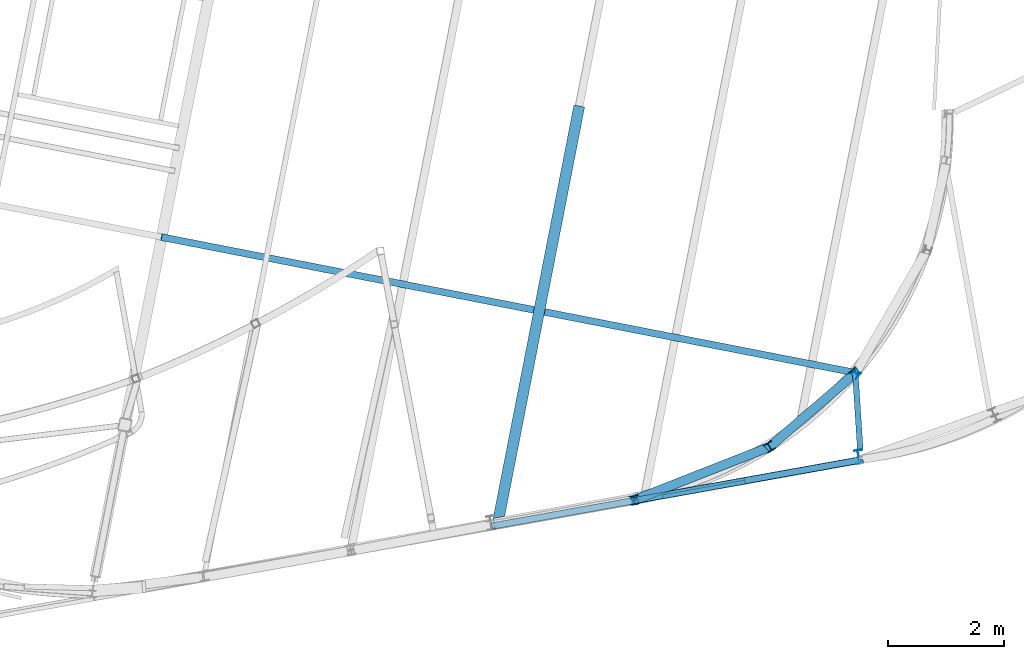
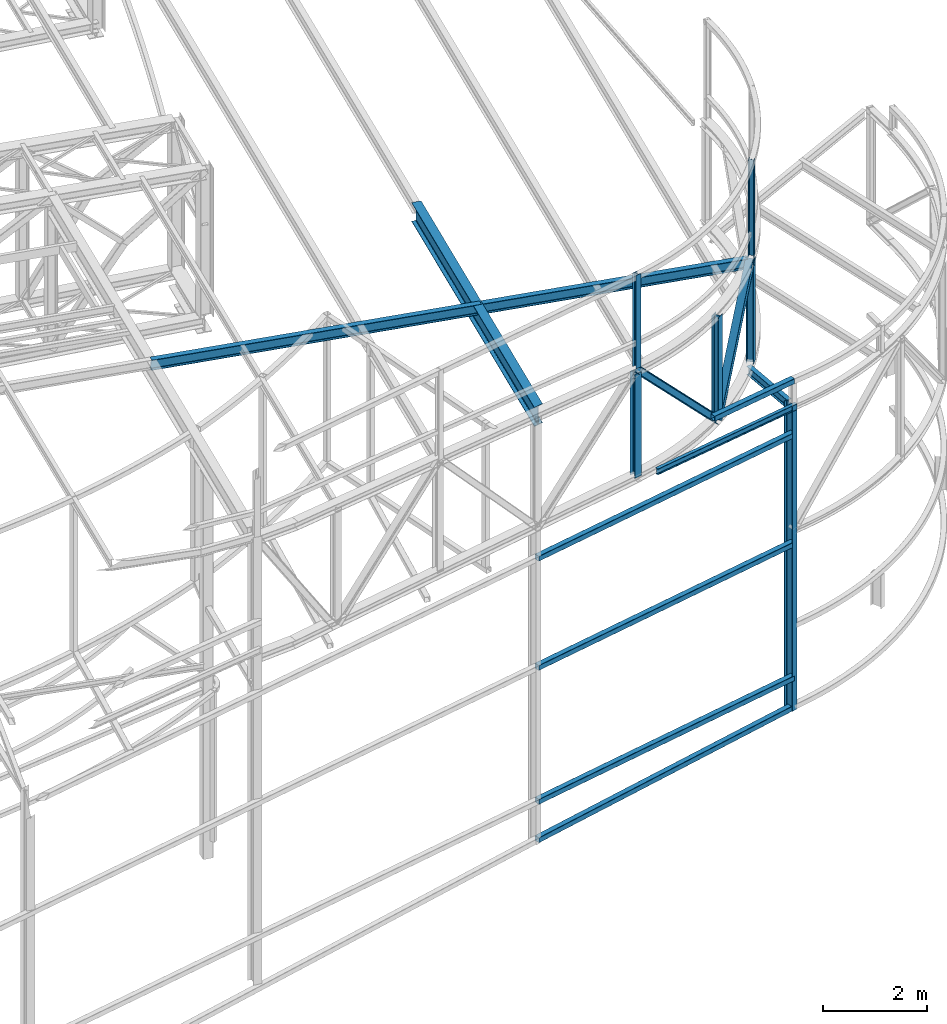
# One storey, part 58 of 215: 15 beams, 2 members, 17 elements without a shape of their own.
"""IFC2X3 building model written with IfcOpenShell, lengths in millimetres."""

from ifc_helpers import new_model, si_unit, frame, origin_with_axes, origin_2d_with_axis, place, context, subcontext, project, spatial, hollow_rectangle, i_section, extrude, clip, halfspace, material, type_object, element, aggregate, save


model = new_model("IFC2X3")

# Units and contexts
model_context = context("Model", 3, precision=1e-05, world=origin_with_axes())
body_context = subcontext(model_context, "Body", "Model", "MODEL_VIEW")
ifc_project = project(units=[si_unit("LENGTHUNIT", "METRE", prefix="MILLI"), si_unit("AREAUNIT", "SQUARE_METRE"), si_unit("VOLUMEUNIT", "CUBIC_METRE"), si_unit("MASSUNIT", "GRAM", prefix="KILO"), si_unit("TIMEUNIT", "SECOND"), si_unit("PLANEANGLEUNIT", "RADIAN"), si_unit("SOLIDANGLEUNIT", "STERADIAN"), si_unit("THERMODYNAMICTEMPERATUREUNIT", "DEGREE_CELSIUS"), si_unit("LUMINOUSINTENSITYUNIT", "LUMEN")], contexts=[model_context])

# Site, building, storey
site_placement = place(None, origin_with_axes())
site = spatial("IfcSite", under=ifc_project, at=site_placement, CompositionType="ELEMENT")
building_placement = place(site_placement, origin_with_axes())
building = spatial("IfcBuilding", under=site, at=building_placement, Name="Undefined", CompositionType="ELEMENT")
storey_placement = place(building_placement, origin_with_axes())
storey = spatial("IfcBuildingStorey", under=building, at=storey_placement, Name="Undefined", CompositionType="ELEMENT", Elevation=0.0)

# Assembly, beam
assembly_1_placement = place(storey_placement, origin_with_axes())
assembly_1 = element("IfcElementAssembly", 1, at=assembly_1_placement, inside=storey, Name="Steel Assembly", AssemblyPlace="NOTDEFINED", PredefinedType="RIGID_FRAME")
ifc_material = material(Name="STEEL/S275JR")
beam_type_1 = type_object("IfcBeamType", Name="IPE240", PredefinedType="NOTDEFINED")
beam_1_placement = place(assembly_1_placement, frame((97347.3851867053, 4087.84249486251, 9374.31892588978), z_axis=(-0.1771386489551, 0.98418590675053, -1.00000033828228e-09), x_axis=(0.0, 0.0, -1.0)))
beam_1 = element("IfcBeam", 2, at=beam_1_placement, type_object=beam_type_1, material=ifc_material, Name="MONTANT", ObjectType="IPE240", context=body_context, shape_type="Clipping", body=[
    clip(extrude(i_section(OverallWidth=120.0, OverallDepth=240.0, WebThickness=6.199999809, FlangeThickness=9.800000191, FilletRadius=15.0, at=origin_2d_with_axis()), frame((7146.48272238819, 1.84732248622022e-22, -1.47785798897617e-21), z_axis=(-1.0, 0.0, 0.0), x_axis=(-6.93889390390723e-18, -1.0, -3.46944695195361e-18)), (0.0, 0.0, 1.0), 7146.5), halfspace(frame((7147.85210151617, 93.6102312018338, -108.961109447533), z_axis=(-0.999134504355505, 0.0415961747295458, 2.13107609228816e-05), x_axis=(-1.00009037889739e-09, -0.000512348971731184, 0.999999868749257)), True)),
])
aggregate(assembly_1, [beam_1])

assembly_2_placement = place(storey_placement, origin_with_axes())
assembly_2 = element("IfcElementAssembly", 3, at=assembly_2_placement, inside=storey, Name="Steel Assembly", AssemblyPlace="NOTDEFINED", PredefinedType="RIGID_FRAME")
beam_2_placement = place(assembly_2_placement, frame((97223.4923669423, 5546.1113580424, 11815.5512887508), z_axis=(0.0304080349965938, -0.00594450399933318, 0.999519891888024), x_axis=(-0.980951221876683, 0.191767344975893, 0.0309836359961049)))
beam_2 = element("IfcBeam", 4, at=beam_2_placement, type_object=beam_type_1, material=ifc_material, Name="TRAVERSE", ObjectType="IPE240", context=body_context, shape_type="SweptSolid", body=[
    extrude(i_section(OverallWidth=120.0, OverallDepth=240.0, WebThickness=6.199999809, FlangeThickness=9.800000191, FilletRadius=15.0, at=origin_2d_with_axis()), frame((12102.0453081629, 2.8537076156674e-12, 8.39748084136206e-14), z_axis=(-1.0, 0.0, 0.0), x_axis=(-6.93889390390723e-18, -1.0, -3.46944695195361e-18)), (0.0, 0.0, 1.0), 12102.0),
])
aggregate(assembly_2, [beam_2])

assembly_3_placement = place(storey_placement, origin_with_axes())
assembly_3 = element("IfcElementAssembly", 5, at=assembly_3_placement, inside=storey, Name="Steel Assembly", AssemblyPlace="NOTDEFINED", PredefinedType="RIGID_FRAME")
beam_type_2 = type_object("IfcBeamType", PredefinedType="NOTDEFINED")
beam_3_placement = place(assembly_3_placement, frame((97357.4855771362, 4028.69337926281, 9936.18618551114), z_axis=(0.0108940300050036, 0.0019528030008978, 0.999938751459653), x_axis=(-0.984250728592777, -0.176431317927004, 0.0110676699954206)))
beam_3 = element("IfcBeam", 6, at=beam_3_placement, type_object=beam_type_2, material=ifc_material, Name="LISSE", context=body_context, shape_type="SweptSolid", body=[
    extrude(hollow_rectangle(XDim=120.0, YDim=120.0, WallThickness=4.0, InnerFilletRadius=4.0, OuterFilletRadius=8.0, at=origin_2d_with_axis()), frame((2004.11588056568, 1.47251628963692e-14, 1.81898940354586e-12), z_axis=(-1.0, 0.0, 0.0), x_axis=(-6.93889390390723e-18, -1.0, -3.46944695195361e-18)), (0.0, 0.0, 1.0), 2004.1),
])
aggregate(assembly_3, [beam_3])

assembly_4_placement = place(storey_placement, origin_with_axes())
assembly_4 = element("IfcElementAssembly", 7, at=assembly_4_placement, inside=storey, Name="Steel Assembly", AssemblyPlace="NOTDEFINED", PredefinedType="RIGID_FRAME")
beam_type_3 = type_object("IfcBeamType", PredefinedType="NOTDEFINED")
beam_4_placement = place(assembly_4_placement, frame((91037.8229060199, 2893.15712750791, 2980.9622243979), z_axis=(-0.176633325081884, 0.98427672345628, -1.15190000054747e-05), x_axis=(0.98427672355278, 0.176633324919744, 0.0)))
beam_4 = element("IfcBeam", 8, at=beam_4_placement, type_object=beam_type_3, material=ifc_material, Name="LISSE", context=body_context, shape_type="SweptSolid", body=[
    extrude(hollow_rectangle(XDim=120.0, YDim=120.0, WallThickness=5.0, InnerFilletRadius=5.0, OuterFilletRadius=10.0, at=origin_2d_with_axis()), frame((6421.60160180629, -4.54744631232399e-13, 3.45974355825933e-12), z_axis=(-1.0, 0.0, 0.0), x_axis=(-6.93889390390723e-18, -1.0, -3.46944695195361e-18)), (0.0, 0.0, 1.0), 6421.6),
])
aggregate(assembly_4, [beam_4])

assembly_5_placement = place(storey_placement, origin_with_axes())
assembly_5 = element("IfcElementAssembly", 9, at=assembly_5_placement, inside=storey, Name="Steel Assembly", AssemblyPlace="NOTDEFINED", PredefinedType="RIGID_FRAME")
beam_5_placement = place(assembly_5_placement, frame((91037.6728468908, 2894.57214630416, 2080.37507932096), z_axis=(-0.176634917931537, 0.984276437618519, -1.07849999957617e-05), x_axis=(0.983738704753266, 0.176538779955722, 0.0330487509917109)))
beam_5 = element("IfcBeam", 10, at=beam_5_placement, type_object=beam_type_3, material=ifc_material, Name="LISSE", context=body_context, shape_type="SweptSolid", body=[
    extrude(hollow_rectangle(XDim=120.0, YDim=120.0, WallThickness=5.0, InnerFilletRadius=5.0, OuterFilletRadius=10.0, at=origin_2d_with_axis()), frame((6354.06246759714, 1.83283510121777e-13, -7.68668195172968e-14), z_axis=(-1.0, 0.0, 0.0), x_axis=(-6.93889390390723e-18, -1.0, -3.46944695195361e-18)), (0.0, 0.0, 1.0), 6354.1),
])
aggregate(assembly_5, [beam_5])

assembly_6_placement = place(storey_placement, origin_with_axes())
assembly_6 = element("IfcElementAssembly", 11, at=assembly_6_placement, inside=storey, Name="Steel Assembly", AssemblyPlace="NOTDEFINED", PredefinedType="RIGID_FRAME")
beam_6_placement = place(assembly_6_placement, frame((91034.3598653981, 2893.97881739079, 6117.50421487598), z_axis=(-0.176633325081884, 0.98427672345628, -1.15190000054747e-05), x_axis=(0.98427672355278, 0.176633324919744, 0.0)))
beam_6 = element("IfcBeam", 12, at=beam_6_placement, type_object=beam_type_3, material=ifc_material, Name="LISSE", context=body_context, shape_type="SweptSolid", body=[
    extrude(hollow_rectangle(XDim=120.0, YDim=120.0, WallThickness=5.0, InnerFilletRadius=5.0, OuterFilletRadius=10.0, at=origin_2d_with_axis()), frame((6421.60160180629, -4.54744631232399e-13, 3.45974355825933e-12), z_axis=(-1.0, 0.0, 0.0), x_axis=(-6.93889390390723e-18, -1.0, -3.46944695195361e-18)), (0.0, 0.0, 1.0), 6421.6),
])
aggregate(assembly_6, [beam_6])

assembly_7_placement = place(storey_placement, origin_with_axes())
assembly_7 = element("IfcElementAssembly", 13, at=assembly_7_placement, inside=storey, Name="Steel Assembly", AssemblyPlace="NOTDEFINED", PredefinedType="RIGID_FRAME")
beam_7_placement = place(assembly_7_placement, frame((91034.3598658139, 2893.97881746567, 8675.00421487628), z_axis=(-0.176633325081884, 0.98427672345628, -1.15190000054747e-05), x_axis=(0.98427672355278, 0.176633324919744, 0.0)))
beam_7 = element("IfcBeam", 14, at=beam_7_placement, type_object=beam_type_3, material=ifc_material, Name="LISSE", context=body_context, shape_type="SweptSolid", body=[
    extrude(hollow_rectangle(XDim=120.0, YDim=120.0, WallThickness=5.0, InnerFilletRadius=5.0, OuterFilletRadius=10.0, at=origin_2d_with_axis()), frame((6421.60160180629, -4.54744631232399e-13, 3.45974355825933e-12), z_axis=(-1.0, 0.0, 0.0), x_axis=(-6.93889390390723e-18, -1.0, -3.46944695195361e-18)), (0.0, 0.0, 1.0), 6421.6),
])
aggregate(assembly_7, [beam_7])

assembly_8_placement = place(storey_placement, origin_with_axes())
assembly_8 = element("IfcElementAssembly", 15, at=assembly_8_placement, inside=storey, Name="Steel Assembly", AssemblyPlace="NOTDEFINED", PredefinedType="RIGID_FRAME")
beam_type_4 = type_object("IfcBeamType", Name="HEA120", PredefinedType="NOTDEFINED")
beam_8_placement = place(assembly_8_placement, frame((97306.0931415402, 5517.42596147959, 14219.9969989793), z_axis=(-0.744310613284674, 0.667833595255429, -1.00000033891823e-09), x_axis=(0.0, 0.0, -1.0)))
beam_8 = element("IfcBeam", 16, at=beam_8_placement, type_object=beam_type_4, material=ifc_material, ObjectType="HEA120", context=body_context, shape_type="SweptSolid", body=[
    extrude(i_section(OverallWidth=120.0, OverallDepth=114.0, WebThickness=5.0, FlangeThickness=8.0, FilletRadius=12.0, at=origin_2d_with_axis()), frame((2247.84108097061, -2.32421320284891e-22, -4.64842640569783e-22), z_axis=(-1.0, 0.0, 0.0), x_axis=(-6.93889390390723e-18, -1.0, -3.46944695195361e-18)), (0.0, 0.0, 1.0), 2247.8),
])
aggregate(assembly_8, [beam_8])

assembly_9_placement = place(storey_placement, origin_with_axes())
assembly_9 = element("IfcElementAssembly", 17, at=assembly_9_placement, inside=storey, Name="Steel Assembly", AssemblyPlace="NOTDEFINED", PredefinedType="RIGID_FRAME")
beam_9_placement = place(assembly_9_placement, frame((93489.7388641986, 3316.10962350602, 14219.9952001423), z_axis=(-0.176370469989763, 0.984323857942898, -1.00000033847774e-09), x_axis=(0.0, 0.0, -1.0)))
beam_9 = element("IfcBeam", 18, at=beam_9_placement, type_object=beam_type_4, material=ifc_material, ObjectType="HEA120", context=body_context, shape_type="SweptSolid", body=[
    extrude(i_section(OverallWidth=120.0, OverallDepth=114.0, WebThickness=5.0, FlangeThickness=8.0, FilletRadius=12.0, at=origin_2d_with_axis()), frame((2184.35345466472, 5.64642133956838e-23, 0.0), z_axis=(-1.0, 0.0, 0.0), x_axis=(-6.93889390390723e-18, -1.0, -3.46944695195361e-18)), (0.0, 0.0, 1.0), 2184.4),
])
aggregate(assembly_9, [beam_9])

assembly_10_placement = place(storey_placement, origin_with_axes())
assembly_10 = element("IfcElementAssembly", 19, at=assembly_10_placement, inside=storey, Name="Steel Assembly", AssemblyPlace="NOTDEFINED", PredefinedType="RIGID_FRAME")
beam_type_5 = type_object("IfcBeamType", Name="IPE200", PredefinedType="NOTDEFINED")
beam_10_placement = place(assembly_10_placement, frame((97375.1483001291, 4189.80037494089, 9274.86486744819), z_axis=(-0.000592520999730379, 0.00915904199585307, 0.999957879547225), x_axis=(-0.0645549180263912, 0.99787194740787, -0.00917818800375124)))
beam_10 = element("IfcBeam", 20, at=beam_10_placement, type_object=beam_type_5, material=ifc_material, ObjectType="IPE200", context=body_context, shape_type="SweptSolid", body=[
    extrude(i_section(OverallWidth=100.0, OverallDepth=200.0, WebThickness=5.599999905, FlangeThickness=8.5, FilletRadius=12.0, at=origin_2d_with_axis()), frame((1398.69519395717, -1.45635585813346e-11, 1.81898940354586e-12), z_axis=(-1.0, 0.0, 0.0), x_axis=(-6.93889390390723e-18, -1.0, -3.46944695195361e-18)), (0.0, 0.0, 1.0), 1398.7),
])
aggregate(assembly_10, [beam_10])

assembly_11_placement = place(storey_placement, origin_with_axes())
assembly_11 = element("IfcElementAssembly", 21, at=assembly_11_placement, inside=storey, Name="Steel Assembly", AssemblyPlace="NOTDEFINED", PredefinedType="RIGID_FRAME")
beam_type_6 = type_object("IfcBeamType", Name="HEA160", PredefinedType="NOTDEFINED")
beam_11_placement = place(assembly_11_placement, frame((97291.9498763033, 5530.11328014931, 11899.608263482), z_axis=(-0.744328553314094, 0.667813600281807, 0.0), x_axis=(0.0, 0.0, -1.0)))
beam_11 = element("IfcBeam", 22, at=beam_11_placement, type_object=beam_type_6, material=ifc_material, Name="MONTANT", ObjectType="HEA160", context=body_context, shape_type="SweptSolid", body=[
    extrude(i_section(OverallWidth=160.0, OverallDepth=152.0, WebThickness=6.0, FlangeThickness=9.0, FilletRadius=15.0, at=origin_2d_with_axis()), frame((2424.84582833439, 0.0, 0.0), z_axis=(-1.0, 0.0, 0.0), x_axis=(-6.93889390390723e-18, -1.0, -3.46944695195361e-18)), (0.0, 0.0, 1.0), 2424.8),
])
aggregate(assembly_11, [beam_11])

assembly_12_placement = place(storey_placement, origin_with_axes())
assembly_12 = element("IfcElementAssembly", 23, at=assembly_12_placement, inside=storey, Name="Steel Assembly", AssemblyPlace="NOTDEFINED", PredefinedType="RIGID_FRAME")
beam_12_placement = place(assembly_12_placement, frame((95814.2606943385, 4256.96033970329, 11866.7940308999), z_axis=(-0.514968644811788, 0.857209014686705, -7.48000000111837e-07), x_axis=(2.07100000193842e-06, 3.72000000031297e-07, -0.999999999997786)))
beam_12 = element("IfcBeam", 24, at=beam_12_placement, type_object=beam_type_6, material=ifc_material, Name="MONTANT", ObjectType="HEA160", context=body_context, shape_type="SweptSolid", body=[
    extrude(i_section(OverallWidth=160.0, OverallDepth=152.0, WebThickness=6.0, FlangeThickness=9.0, FilletRadius=15.0, at=origin_2d_with_axis()), frame((2391.95936427624, -1.01303419501771e-18, -7.59775646263285e-19), z_axis=(-1.0, 0.0, 0.0), x_axis=(-6.93889390390723e-18, -1.0, -3.46944695195361e-18)), (0.0, 0.0, 1.0), 2392.0),
])
aggregate(assembly_12, [beam_12])

assembly_13_placement = place(storey_placement, origin_with_axes())
assembly_13 = element("IfcElementAssembly", 25, at=assembly_13_placement, inside=storey, Name="Steel Assembly", AssemblyPlace="NOTDEFINED", PredefinedType="RIGID_FRAME")
beam_13_placement = place(assembly_13_placement, frame((93484.7578346869, 3343.89281977949, 11903.5961467306), z_axis=(-0.176396911950543, 0.984319119724042, 0.0), x_axis=(0.0, 0.0, -1.0)))
beam_13 = element("IfcBeam", 26, at=beam_13_placement, type_object=beam_type_6, material=ifc_material, Name="MONTANT", ObjectType="HEA160", context=body_context, shape_type="SweptSolid", body=[
    extrude(i_section(OverallWidth=160.0, OverallDepth=152.0, WebThickness=6.0, FlangeThickness=9.0, FilletRadius=15.0, at=origin_2d_with_axis()), frame((2428.60117896079, 0.0, 0.0), z_axis=(-1.0, 0.0, 0.0), x_axis=(-6.93889390390723e-18, -1.0, -3.46944695195361e-18)), (0.0, 0.0, 1.0), 2428.6),
])
aggregate(assembly_13, [beam_13])

# Assembly, member
assembly_14_placement = place(storey_placement, origin_with_axes())
assembly_14 = element("IfcElementAssembly", 27, at=assembly_14_placement, inside=storey, Name="Steel Assembly", AssemblyPlace="NOTDEFINED", PredefinedType="RIGID_FRAME")
member_type = type_object("IfcMemberType", Name="HEA160", PredefinedType="NOTDEFINED")
member_1_placement = place(assembly_14_placement, frame((93494.5834124585, 3345.64250318878, 11968.0985030029), z_axis=(0.666872456981407, 0.261990277992694, 0.697597462980545), x_axis=(0.649288333052176, 0.255082106020498, -0.716489902057576)))
member_1 = element("IfcMember", 28, at=member_1_placement, type_object=member_type, material=ifc_material, Name="LISSE", ObjectType="HEA160", context=body_context, shape_type="SweptSolid", body=[
    extrude(i_section(OverallWidth=160.0, OverallDepth=152.0, WebThickness=6.0, FlangeThickness=9.0, FilletRadius=15.0, at=origin_2d_with_axis()), frame((3572.64445611391, -3.84535481172994e-12, 3.96643213397707e-13), z_axis=(-1.0, 0.0, 0.0), x_axis=(-6.93889390390723e-18, -1.0, -3.46944695195361e-18)), (0.0, 0.0, 1.0), 3572.6),
])
aggregate(assembly_14, [member_1])

assembly_15_placement = place(storey_placement, origin_with_axes())
assembly_15 = element("IfcElementAssembly", 29, at=assembly_15_placement, inside=storey, Name="Steel Assembly", AssemblyPlace="NOTDEFINED", PredefinedType="RIGID_FRAME")
member_2_placement = place(assembly_15_placement, frame((97291.9498765079, 5530.11328021747, 11899.6100006151), z_axis=(-0.596512573975023, -0.513945406978486, 0.616468058974195), x_axis=(-0.467031151881876, -0.402386345898228, -0.787379915800854)))
member_2 = element("IfcMember", 30, at=member_2_placement, type_object=member_type, material=ifc_material, Name="LISSE", ObjectType="HEA160", context=body_context, shape_type="SweptSolid", body=[
    extrude(i_section(OverallWidth=160.0, OverallDepth=152.0, WebThickness=6.0, FlangeThickness=9.0, FilletRadius=15.0, at=origin_2d_with_axis()), frame((3164.00650386431, -5.63237469540029e-14, 1.75637643532696e-13), z_axis=(-1.0, 0.0, 0.0), x_axis=(-6.93889390390723e-18, -1.0, -3.46944695195361e-18)), (0.0, 0.0, 1.0), 3164.0),
])
aggregate(assembly_15, [member_2])

# Assembly, beam
assembly_16_placement = place(storey_placement, origin_with_axes())
assembly_16 = element("IfcElementAssembly", 31, at=assembly_16_placement, inside=storey, Name="Steel Assembly", AssemblyPlace="NOTDEFINED", PredefinedType="RIGID_FRAME")
beam_type_7 = type_object("IfcBeamType", Name="IPE140", PredefinedType="NOTDEFINED")
beam_14_placement = place(assembly_16_placement, frame((93978.9215553282, 3395.42736838611, 9362.40486158433), z_axis=(-0.0129701229935968, -0.00233224299884728, -0.999913164505861), x_axis=(0.984161693705293, 0.176782626947063, -0.0131781429960537)))
beam_14 = element("IfcBeam", 32, at=beam_14_placement, type_object=beam_type_7, material=ifc_material, Name="LISSE", ObjectType="IPE140", context=body_context, shape_type="SweptSolid", body=[
    extrude(i_section(OverallWidth=73.0, OverallDepth=140.0, WebThickness=4.699999809, FlangeThickness=6.900000095, FilletRadius=7.0, at=origin_2d_with_axis()), frame((3497.75524470548, 5.37948070112292e-14, -6.06763813621163e-15), z_axis=(-1.0, 0.0, 0.0), x_axis=(-6.93889390390723e-18, -1.0, -3.46944695195361e-18)), (0.0, 0.0, 1.0), 3497.8),
])
aggregate(assembly_16, [beam_14])

assembly_17_placement = place(storey_placement, origin_with_axes())
assembly_17 = element("IfcElementAssembly", 33, at=assembly_17_placement, inside=storey, Name="Steel Assembly", AssemblyPlace="NOTDEFINED", PredefinedType="RIGID_FRAME")
beam_type_8 = type_object("IfcBeamType", Name="IPE450", PredefinedType="NOTDEFINED")
beam_15_placement = place(assembly_17_placement, frame((91199.1065605312, 3261.12460022205, 11878.2045556255), z_axis=(0.0, 0.0, 1.0), x_axis=(0.191859470081235, 0.981422408415534, 0.0)))
beam_15 = element("IfcBeam", 34, at=beam_15_placement, type_object=beam_type_8, material=ifc_material, Name="POUTRE", ObjectType="IPE450", context=body_context, shape_type="Clipping", body=[
    clip(extrude(i_section(OverallWidth=190.0, OverallDepth=450.0, WebThickness=9.399999619, FlangeThickness=14.60000038, FilletRadius=21.0, at=origin_2d_with_axis()), frame((6990.84376516687, 0.0, 0.0), z_axis=(-1.0, 0.0, 0.0), x_axis=(-6.93889390390723e-18, -1.0, -3.46944695195361e-18)), (0.0, 0.0, 1.0), 7285.7), halfspace(frame((-225.631794414883, 10.679389584926, -11878.2045556185), z_axis=(0.932135446549041, 0.362109802804093, 0.0), x_axis=(0.0, 0.0, -1.0)), True)),
])
aggregate(assembly_17, [beam_15])

save(model, "model.ifc")
